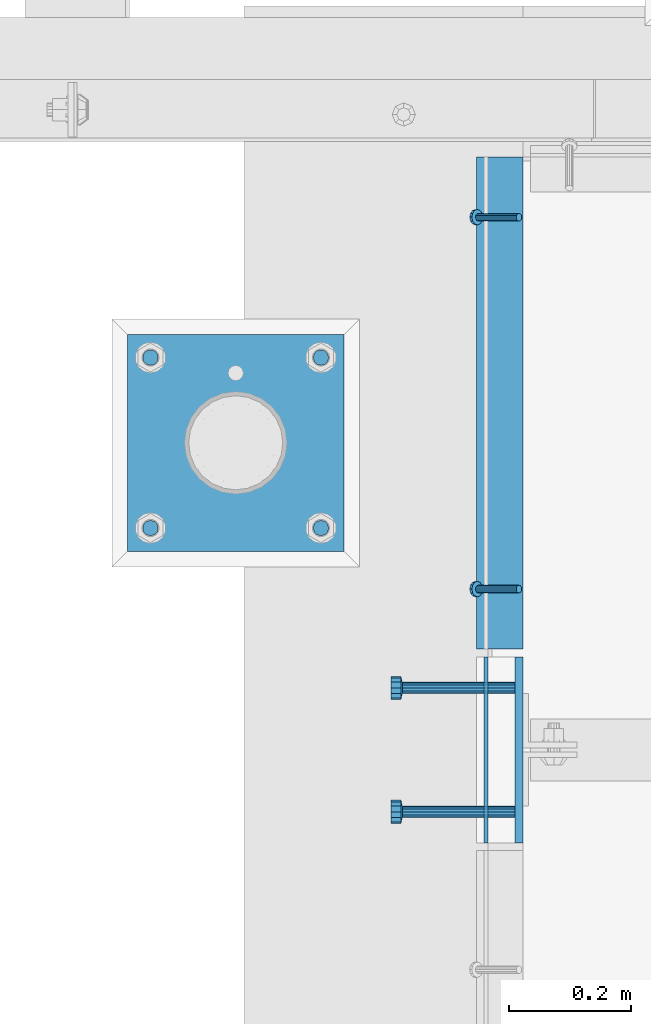
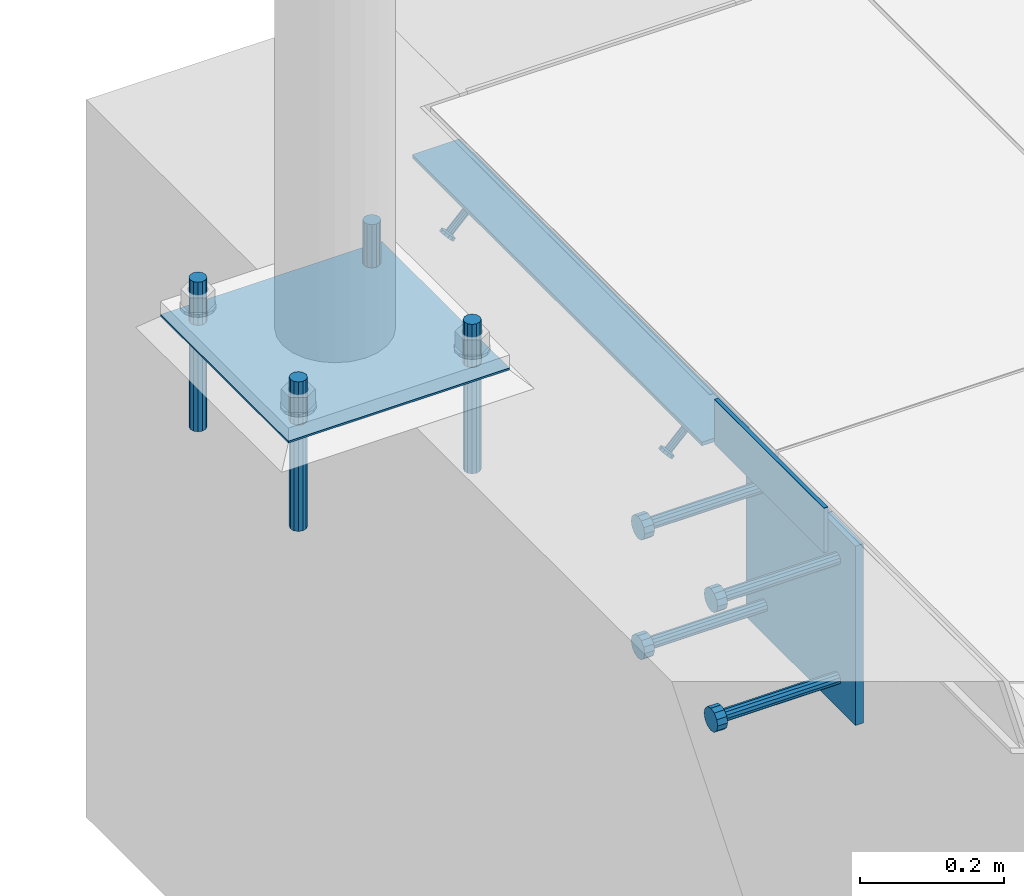
# One storey, part 2018 of 3843: 12 beams, 2 members, 3 elements without a shape of their own.
"""IFC2X3 building model written with IfcOpenShell, lengths in millimetres."""

from ifc_helpers import new_model, si_unit, frame, origin_with_axes, place, context, subcontext, project, spatial, faceted_brep, material, type_object, element, aggregate, save


model = new_model("IFC2X3")

# Units and contexts
model_context = context("Model", 3, precision=1e-05, world=origin_with_axes())
body_context = subcontext(model_context, "Body", "Model", "MODEL_VIEW")
ifc_project = project(units=[si_unit("LENGTHUNIT", "METRE", prefix="MILLI"), si_unit("AREAUNIT", "SQUARE_METRE"), si_unit("VOLUMEUNIT", "CUBIC_METRE"), si_unit("MASSUNIT", "GRAM", prefix="KILO"), si_unit("TIMEUNIT", "SECOND"), si_unit("PLANEANGLEUNIT", "RADIAN"), si_unit("SOLIDANGLEUNIT", "STERADIAN"), si_unit("THERMODYNAMICTEMPERATUREUNIT", "DEGREE_CELSIUS"), si_unit("LUMINOUSINTENSITYUNIT", "LUMEN")], contexts=[model_context])

# Site, building, storey
site_placement = place(None, origin_with_axes())
site = spatial("IfcSite", under=ifc_project, at=site_placement, CompositionType="ELEMENT")
building_placement = place(site_placement, origin_with_axes())
building = spatial("IfcBuilding", under=site, at=building_placement, Name="Undefined", CompositionType="ELEMENT")
storey_placement = place(building_placement, origin_with_axes())
storey = spatial("IfcBuildingStorey", under=building, at=storey_placement, Name="Undefined", CompositionType="ELEMENT", Elevation=0.0)

# Assembly, members
assembly_1_placement = place(storey_placement, origin_with_axes())
assembly_1 = element("IfcElementAssembly", 1, at=assembly_1_placement, inside=storey, Name="ANGLE", AssemblyPlace="NOTDEFINED", PredefinedType="RIGID_FRAME")
ifc_material_1 = material(Name="STEEL/A108")
member_type = type_object("IfcMemberType", PredefinedType="NOTDEFINED")
member_1_placement = place(assembly_1_placement, frame((41411.5249999999, 24272.8750946045, 30397.4500030518), z_axis=(0.0, -1.0, 0.0), x_axis=(-0.707106781186548, 0.0, -0.707106781186548)))
member_1 = element("IfcMember", 2, at=member_1_placement, type_object=member_type, material=ifc_material_1, Name="HEADED STUD ANCHOR", context=body_context, shape_type="Brep", body=[
    faceted_brep([(7.27595761418343e-12, -3.18000006675175, 5.5), (0.0, -5.49999999998363, 3.1800000667572), (94.4879985803855, -5.50000000011278, 3.1800000667572), (94.4879985803782, -3.18000006687362, 5.5), (0.0, -6.3499999046162, 0.0), (94.4879985803855, -6.34999990474535, 0.0), (0.0, -5.49999999998363, -3.1800000667572), (94.4879985803855, -5.50000000011278, -3.1800000667572), (7.27595761418343e-12, -3.18000006675175, -5.5), (94.4879985803782, -3.18000006687362, -5.5), (7.27595761418343e-12, -1.81898940354586e-12, -6.34999990463257), (94.4879985803782, -1.20053300634027e-10, -6.34999990463257), (0.0, 3.18000006675175, -5.5), (94.4879985803709, 3.18000006663351, -5.5), (7.27595761418343e-12, 5.49999999998363, -3.1800000667572), (94.4879985803709, 5.49999999987267, -3.1800000667572), (7.27595761418343e-12, 6.3499999046162, 0.0), (94.4879985803673, 6.34999990450706, 0.0), (7.27595761418343e-12, 5.49999999998363, 3.1800000667572), (94.4879985803709, 5.49999999987267, 3.1800000667572), (0.0, 3.18000006675175, 5.5), (94.4879985803709, 3.18000006663351, 5.5), (7.27595761418343e-12, -1.81898940354586e-12, 6.34999990463257), (94.4879985803782, -1.20053300634027e-10, 6.34999990463257), (96.5199985498621, -10.9899997712273, 6.34999990463257), (96.5199985498548, -6.34000015270249, 10.9899997711182), (96.5199985498621, -12.6999998093743, 0.0), (96.5199985498621, -10.9899997712273, -6.34999990463257), (96.5199985498548, -6.34000015270249, -10.9899997711182), (96.5199985498475, -1.21872290037572e-10, -12.6899995803833), (96.5199985498402, 6.34000015245874, -10.9899997711182), (96.519998549833, 10.9899997709817, -6.34999990463257), (96.519998549833, 12.6999998091305, 0.0), (96.519998549833, 10.9899997709817, 6.34999990463257), (96.5199985498402, 6.34000015245874, 10.9899997711182), (96.5199985498475, -1.21872290037572e-10, 12.6899995803833), (101.599998473539, -10.9899997712328, 6.34999990463257), (101.599998473532, -6.34000015270976, 10.9899997711182), (101.599998473539, -12.6999998093797, 0.0), (101.599998473539, -10.9899997712328, -6.34999990463257), (101.599998473532, -6.34000015270976, -10.9899997711182), (101.599998473524, -1.29148247651756e-10, -12.6899995803833), (101.599998473517, 6.34000015245329, -10.9899997711182), (101.59999847351, 10.9899997709763, -6.34999990463257), (101.599998473503, 12.6999998091196, 0.0), (101.59999847351, 10.9899997709763, 6.34999990463257), (101.599998473517, 6.34000015245329, 10.9899997711182), (101.599998473524, -1.29148247651756e-10, 12.6899995803833)], [[[0, 1, 2, 3]], [[1, 4, 5, 2]], [[4, 6, 7, 5]], [[6, 8, 9, 7]], [[8, 10, 11, 9]], [[10, 12, 13, 11]], [[12, 14, 15, 13]], [[14, 16, 17, 15]], [[16, 18, 19, 17]], [[18, 20, 21, 19]], [[20, 22, 23, 21]], [[22, 0, 3, 23]], [[22, 20, 18, 16, 14, 12, 10, 8, 6, 4, 1, 0]], [[3, 2, 24, 25]], [[2, 5, 26, 24]], [[5, 7, 27, 26]], [[7, 9, 28, 27]], [[9, 11, 29, 28]], [[11, 13, 30, 29]], [[13, 15, 31, 30]], [[15, 17, 32, 31]], [[17, 19, 33, 32]], [[19, 21, 34, 33]], [[21, 23, 35, 34]], [[23, 3, 25, 35]], [[25, 24, 36, 37]], [[24, 26, 38, 36]], [[26, 27, 39, 38]], [[27, 28, 40, 39]], [[28, 29, 41, 40]], [[29, 30, 42, 41]], [[30, 31, 43, 42]], [[31, 32, 44, 43]], [[32, 33, 45, 44]], [[33, 34, 46, 45]], [[34, 35, 47, 46]], [[35, 25, 37, 47]], [[38, 39, 40, 41, 42, 43, 44, 45, 46, 47, 37, 36]]]),
])
member_2_placement = place(assembly_1_placement, frame((41411.5249999999, 24882.4750946045, 30397.4500030518), z_axis=(0.0, -1.0, 0.0), x_axis=(-0.707106781186548, 0.0, -0.707106781186548)))
member_2 = element("IfcMember", 3, at=member_2_placement, type_object=member_type, material=ifc_material_1, Name="HEADED STUD ANCHOR", context=body_context, shape_type="Brep", body=[
    faceted_brep([(7.27595761418343e-12, -3.18000006675175, 5.5), (0.0, -5.49999999998363, 3.1800000667572), (94.4879985803855, -5.50000000011278, 3.1800000667572), (94.4879985803782, -3.18000006687362, 5.5), (0.0, -6.3499999046162, 0.0), (94.4879985803855, -6.34999990474535, 0.0), (0.0, -5.49999999998363, -3.1800000667572), (94.4879985803855, -5.50000000011278, -3.1800000667572), (7.27595761418343e-12, -3.18000006675175, -5.5), (94.4879985803782, -3.18000006687362, -5.5), (7.27595761418343e-12, -1.81898940354586e-12, -6.34999990463257), (94.4879985803782, -1.20053300634027e-10, -6.34999990463257), (0.0, 3.18000006675175, -5.5), (94.4879985803709, 3.18000006663351, -5.5), (7.27595761418343e-12, 5.49999999998363, -3.1800000667572), (94.4879985803709, 5.49999999987267, -3.1800000667572), (7.27595761418343e-12, 6.3499999046162, 0.0), (94.4879985803673, 6.34999990450706, 0.0), (7.27595761418343e-12, 5.49999999998363, 3.1800000667572), (94.4879985803709, 5.49999999987267, 3.1800000667572), (0.0, 3.18000006675175, 5.5), (94.4879985803709, 3.18000006663351, 5.5), (7.27595761418343e-12, -1.81898940354586e-12, 6.34999990463257), (94.4879985803782, -1.20053300634027e-10, 6.34999990463257), (96.5199985498621, -10.9899997712273, 6.34999990463257), (96.5199985498548, -6.34000015270249, 10.9899997711182), (96.5199985498621, -12.6999998093743, 0.0), (96.5199985498621, -10.9899997712273, -6.34999990463257), (96.5199985498548, -6.34000015270249, -10.9899997711182), (96.5199985498475, -1.21872290037572e-10, -12.6899995803833), (96.5199985498402, 6.34000015245874, -10.9899997711182), (96.519998549833, 10.9899997709817, -6.34999990463257), (96.519998549833, 12.6999998091305, 0.0), (96.519998549833, 10.9899997709817, 6.34999990463257), (96.5199985498402, 6.34000015245874, 10.9899997711182), (96.5199985498475, -1.21872290037572e-10, 12.6899995803833), (101.599998473539, -10.9899997712328, 6.34999990463257), (101.599998473532, -6.34000015270976, 10.9899997711182), (101.599998473539, -12.6999998093797, 0.0), (101.599998473539, -10.9899997712328, -6.34999990463257), (101.599998473532, -6.34000015270976, -10.9899997711182), (101.599998473524, -1.29148247651756e-10, -12.6899995803833), (101.599998473517, 6.34000015245329, -10.9899997711182), (101.59999847351, 10.9899997709763, -6.34999990463257), (101.599998473503, 12.6999998091196, 0.0), (101.59999847351, 10.9899997709763, 6.34999990463257), (101.599998473517, 6.34000015245329, 10.9899997711182), (101.599998473524, -1.29148247651756e-10, 12.6899995803833)], [[[0, 1, 2, 3]], [[1, 4, 5, 2]], [[4, 6, 7, 5]], [[6, 8, 9, 7]], [[8, 10, 11, 9]], [[10, 12, 13, 11]], [[12, 14, 15, 13]], [[14, 16, 17, 15]], [[16, 18, 19, 17]], [[18, 20, 21, 19]], [[20, 22, 23, 21]], [[22, 0, 3, 23]], [[22, 20, 18, 16, 14, 12, 10, 8, 6, 4, 1, 0]], [[3, 2, 24, 25]], [[2, 5, 26, 24]], [[5, 7, 27, 26]], [[7, 9, 28, 27]], [[9, 11, 29, 28]], [[11, 13, 30, 29]], [[13, 15, 31, 30]], [[15, 17, 32, 31]], [[17, 19, 33, 32]], [[19, 21, 34, 33]], [[21, 23, 35, 34]], [[23, 3, 25, 35]], [[25, 24, 36, 37]], [[24, 26, 38, 36]], [[26, 27, 39, 38]], [[27, 28, 40, 39]], [[28, 29, 41, 40]], [[29, 30, 42, 41]], [[30, 31, 43, 42]], [[31, 32, 44, 43]], [[32, 33, 45, 44]], [[33, 34, 46, 45]], [[34, 35, 47, 46]], [[35, 25, 37, 47]], [[38, 39, 40, 41, 42, 43, 44, 45, 46, 47, 37, 36]]]),
])

# Assembly, beams
assembly_2_placement = place(storey_placement, origin_with_axes())
assembly_2 = element("IfcElementAssembly", 4, at=assembly_2_placement, inside=storey, Name="TEMPLATE", AssemblyPlace="NOTDEFINED", PredefinedType="RIGID_FRAME")
ifc_material_2 = material(Name="STEEL/316 SS")
beam_type_1 = type_object("IfcBeamType", PredefinedType="NOTDEFINED")
beam_1_placement = place(assembly_2_placement, frame((41086.9793884277, 24372.9638262535, 30581.6), z_axis=(1.0, 0.0, 0.0), x_axis=(0.0, 0.0, -1.0)))
beam_1 = element("IfcBeam", 5, at=beam_1_placement, type_object=beam_type_1, material=ifc_material_2, Name="ANCHOR_ROD", context=body_context, shape_type="Brep", body=[
    faceted_brep([(0.0, -12.6999999999971, 0.0), (0.0, -10.9985226280696, -6.34999999999854), (253.999, -10.9985226280696, -6.34999999999854), (253.999, -12.6999999999971, 0.0), (0.0, -6.35000000000582, -10.9985226280623), (253.999, -6.35000000000582, -10.9985226280623), (0.0, 0.0, -12.6999999999971), (253.999, 0.0, -12.6999999999971), (0.0, 6.35000000000582, -10.9985226280623), (253.999, 6.35000000000582, -10.9985226280623), (0.0, 10.9985226280696, -6.34999999999854), (253.999, 10.9985226280696, -6.34999999999854), (0.0, 12.6999999999971, 0.0), (253.999, 12.6999999999971, 0.0), (0.0, 10.9985226280696, 6.34999999999854), (253.999, 10.9985226280696, 6.34999999999854), (0.0, 6.35000000000582, 10.9985226280623), (253.999, 6.35000000000582, 10.9985226280623), (0.0, 0.0, 12.6999999999971), (253.999, 0.0, 12.6999999999971), (0.0, -6.35000000000582, 10.9985226280623), (253.999, -6.35000000000582, 10.9985226280623), (0.0, -10.9985226280696, 6.34999999999854), (253.999, -10.9985226280696, 6.34999999999854)], [[[0, 1, 2, 3]], [[1, 4, 5, 2]], [[4, 6, 7, 5]], [[6, 8, 9, 7]], [[8, 10, 11, 9]], [[10, 12, 13, 11]], [[12, 14, 15, 13]], [[14, 16, 17, 15]], [[16, 18, 19, 17]], [[18, 20, 21, 19]], [[20, 22, 23, 21]], [[22, 0, 3, 23]], [[5, 7, 9, 11, 13, 15, 17, 19, 21, 23, 3, 2]], [[22, 20, 18, 16, 14, 12, 10, 8, 6, 4, 1, 0]]]),
])
beam_2_placement = place(assembly_2_placement, frame((41086.9793884277, 24652.3638262535, 30581.6), z_axis=(-1.0, 0.0, 0.0), x_axis=(0.0, 0.0, -1.0)))
beam_2 = element("IfcBeam", 6, at=beam_2_placement, type_object=beam_type_1, material=ifc_material_2, Name="ANCHOR_ROD", context=body_context, shape_type="Brep", body=[
    faceted_brep([(0.0, -12.6999999999971, 0.0), (0.0, -10.9985226280696, -6.34999999999854), (253.999, -10.9985226280696, -6.34999999999854), (253.999, -12.6999999999971, 0.0), (0.0, -6.35000000000582, -10.9985226280623), (253.999, -6.35000000000582, -10.9985226280623), (0.0, 0.0, -12.6999999999971), (253.999, 0.0, -12.6999999999971), (0.0, 6.35000000000582, -10.9985226280623), (253.999, 6.35000000000582, -10.9985226280623), (0.0, 10.9985226280696, -6.34999999999854), (253.999, 10.9985226280696, -6.34999999999854), (0.0, 12.6999999999971, 0.0), (253.999, 12.6999999999971, 0.0), (0.0, 10.9985226280696, 6.34999999999854), (253.999, 10.9985226280696, 6.34999999999854), (0.0, 6.35000000000582, 10.9985226280623), (253.999, 6.35000000000582, 10.9985226280623), (0.0, 0.0, 12.6999999999971), (253.999, 0.0, 12.6999999999971), (0.0, -6.35000000000582, 10.9985226280623), (253.999, -6.35000000000582, 10.9985226280623), (0.0, -10.9985226280696, 6.34999999999854), (253.999, -10.9985226280696, 6.34999999999854)], [[[0, 1, 2, 3]], [[1, 4, 5, 2]], [[4, 6, 7, 5]], [[6, 8, 9, 7]], [[8, 10, 11, 9]], [[10, 12, 13, 11]], [[12, 14, 15, 13]], [[14, 16, 17, 15]], [[16, 18, 19, 17]], [[18, 20, 21, 19]], [[20, 22, 23, 21]], [[22, 0, 3, 23]], [[5, 7, 9, 11, 13, 15, 17, 19, 21, 23, 3, 2]], [[22, 20, 18, 16, 14, 12, 10, 8, 6, 4, 1, 0]]]),
])
beam_3_placement = place(assembly_2_placement, frame((40807.5793884277, 24372.9638262535, 30581.6), z_axis=(1.0, 0.0, 0.0), x_axis=(0.0, 0.0, -1.0)))
beam_3 = element("IfcBeam", 7, at=beam_3_placement, type_object=beam_type_1, material=ifc_material_2, Name="ANCHOR_ROD", context=body_context, shape_type="Brep", body=[
    faceted_brep([(0.0, -12.6999999999971, 0.0), (0.0, -10.9985226280696, -6.34999999999854), (253.999, -10.9985226280696, -6.34999999999854), (253.999, -12.6999999999971, 0.0), (0.0, -6.35000000000582, -10.9985226280623), (253.999, -6.35000000000582, -10.9985226280623), (0.0, 0.0, -12.6999999999971), (253.999, 0.0, -12.6999999999971), (0.0, 6.35000000000582, -10.9985226280623), (253.999, 6.35000000000582, -10.9985226280623), (0.0, 10.9985226280696, -6.34999999999854), (253.999, 10.9985226280696, -6.34999999999854), (0.0, 12.6999999999971, 0.0), (253.999, 12.6999999999971, 0.0), (0.0, 10.9985226280696, 6.34999999999854), (253.999, 10.9985226280696, 6.34999999999854), (0.0, 6.35000000000582, 10.9985226280623), (253.999, 6.35000000000582, 10.9985226280623), (0.0, 0.0, 12.6999999999971), (253.999, 0.0, 12.6999999999971), (0.0, -6.35000000000582, 10.9985226280623), (253.999, -6.35000000000582, 10.9985226280623), (0.0, -10.9985226280696, 6.34999999999854), (253.999, -10.9985226280696, 6.34999999999854)], [[[0, 1, 2, 3]], [[1, 4, 5, 2]], [[4, 6, 7, 5]], [[6, 8, 9, 7]], [[8, 10, 11, 9]], [[10, 12, 13, 11]], [[12, 14, 15, 13]], [[14, 16, 17, 15]], [[16, 18, 19, 17]], [[18, 20, 21, 19]], [[20, 22, 23, 21]], [[22, 0, 3, 23]], [[5, 7, 9, 11, 13, 15, 17, 19, 21, 23, 3, 2]], [[22, 20, 18, 16, 14, 12, 10, 8, 6, 4, 1, 0]]]),
])
beam_4_placement = place(assembly_2_placement, frame((40807.5793884277, 24652.3638262535, 30581.6), z_axis=(-1.0, 0.0, 0.0), x_axis=(0.0, 0.0, -1.0)))
beam_4 = element("IfcBeam", 8, at=beam_4_placement, type_object=beam_type_1, material=ifc_material_2, Name="ANCHOR_ROD", context=body_context, shape_type="Brep", body=[
    faceted_brep([(0.0, -12.6999999999971, 0.0), (0.0, -10.9985226280696, -6.34999999999854), (253.999, -10.9985226280696, -6.34999999999854), (253.999, -12.6999999999971, 0.0), (0.0, -6.35000000000582, -10.9985226280623), (253.999, -6.35000000000582, -10.9985226280623), (0.0, 0.0, -12.6999999999971), (253.999, 0.0, -12.6999999999971), (0.0, 6.35000000000582, -10.9985226280623), (253.999, 6.35000000000582, -10.9985226280623), (0.0, 10.9985226280696, -6.34999999999854), (253.999, 10.9985226280696, -6.34999999999854), (0.0, 12.6999999999971, 0.0), (253.999, 12.6999999999971, 0.0), (0.0, 10.9985226280696, 6.34999999999854), (253.999, 10.9985226280696, 6.34999999999854), (0.0, 6.35000000000582, 10.9985226280623), (253.999, 6.35000000000582, 10.9985226280623), (0.0, 0.0, 12.6999999999971), (253.999, 0.0, 12.6999999999971), (0.0, -6.35000000000582, 10.9985226280623), (253.999, -6.35000000000582, 10.9985226280623), (0.0, -10.9985226280696, 6.34999999999854), (253.999, -10.9985226280696, 6.34999999999854)], [[[0, 1, 2, 3]], [[1, 4, 5, 2]], [[4, 6, 7, 5]], [[6, 8, 9, 7]], [[8, 10, 11, 9]], [[10, 12, 13, 11]], [[12, 14, 15, 13]], [[14, 16, 17, 15]], [[16, 18, 19, 17]], [[18, 20, 21, 19]], [[20, 22, 23, 21]], [[22, 0, 3, 23]], [[5, 7, 9, 11, 13, 15, 17, 19, 21, 23, 3, 2]], [[22, 20, 18, 16, 14, 12, 10, 8, 6, 4, 1, 0]]]),
])
ifc_material_3 = material(Name="STEEL/A36")
beam_type_2 = type_object("IfcBeamType", PredefinedType="NOTDEFINED")
beam_5_placement = place(assembly_2_placement, frame((41125.0793884277, 24512.6638262535, 30506.9875), z_axis=(0.0, -1.0, 0.0), x_axis=(-1.0, 0.0, 0.0)))
beam_5 = element("IfcBeam", 9, at=beam_5_placement, type_object=beam_type_2, material=ifc_material_3, Name="TEMPLATE", context=body_context, shape_type="Brep", body=[
    faceted_brep([(0.0, 1.58750000000146, -177.800000000003), (0.0, 1.58750000000146, 177.800000000003), (355.600000000006, 1.58750000000146, 177.800000000003), (355.600000000006, 1.58750000000146, -177.800000000003), (0.0, -1.58750000000146, 177.800000000003), (355.600000000006, -1.58750000000146, 177.800000000003), (0.0, -1.58750000000146, -177.800000000003), (355.600000000006, -1.58750000000146, -177.800000000003)], [[[0, 1, 2, 3]], [[1, 4, 5, 2]], [[4, 6, 7, 5]], [[6, 0, 3, 7]], [[5, 7, 3, 2]], [[6, 4, 1, 0]]]),
])
aggregate(assembly_2, [beam_1, beam_2, beam_3, beam_4, beam_5])

assembly_3_placement = place(storey_placement, origin_with_axes())
assembly_3 = element("IfcElementAssembly", 10, at=assembly_3_placement, inside=storey, Name="EMBED PLATE", AssemblyPlace="NOTDEFINED", PredefinedType="RIGID_FRAME")
beam_type_3 = type_object("IfcBeamType", PredefinedType="NOTDEFINED")
beam_6_placement = place(assembly_3_placement, frame((41357.55, 23856.95, 30441.9), z_axis=(0.0, 0.0, 1.0), x_axis=(0.0, 1.0, 0.0)))
beam_6 = element("IfcBeam", 11, at=beam_6_placement, type_object=beam_type_3, material=ifc_material_3, Name="PLATE", context=body_context, shape_type="Brep", body=[
    faceted_brep([(0.0, 3.17500000000291, -38.0999999999985), (0.0, 3.17500000000291, 38.0999999999985), (304.800000000003, 3.17499999999927, 38.0999999999985), (304.800000000003, 3.17499999999927, -38.0999999999985), (0.0, -3.17500000000291, 38.0999999999985), (304.800000000003, -3.17499999999927, 38.0999999999985), (0.0, -3.17500000000291, -38.0999999999985), (304.800000000003, -3.17499999999927, -38.0999999999985)], [[[0, 1, 2, 3]], [[1, 4, 5, 2]], [[4, 6, 7, 5]], [[6, 0, 3, 7]], [[5, 7, 3, 2]], [[6, 4, 1, 0]]]),
])
beam_type_4 = type_object("IfcBeamType", PredefinedType="NOTDEFINED")
beam_7_placement = place(assembly_3_placement, frame((41411.525, 24009.35, 30397.45), z_axis=(0.0, 1.0, 0.0), x_axis=(0.0, 0.0, -1.0)))
beam_7 = element("IfcBeam", 12, at=beam_7_placement, type_object=beam_type_4, material=ifc_material_3, Name="EMBED PLATE", context=body_context, shape_type="Brep", body=[
    faceted_brep([(-1.0550138540566e-10, 6.34999999999854, -152.400000000664), (1.0550138540566e-10, 6.34999999999854, 152.400000000656), (304.799999999999, 6.34999999999854, 152.400000000001), (304.799999999999, 6.34999999999854, -152.400000000001), (1.0550138540566e-10, -6.34999999999854, 152.400000000656), (304.799999999999, -6.34999999999854, 152.400000000001), (-1.0550138540566e-10, -6.34999999999854, -152.400000000664), (304.799999999999, -6.34999999999854, -152.400000000001)], [[[0, 1, 2, 3]], [[1, 4, 5, 2]], [[4, 6, 7, 5]], [[6, 0, 3, 7]], [[5, 7, 3, 2]], [[6, 4, 1, 0]]]),
])

# Beam
beam_type_5 = type_object("IfcBeamType", Name="L3X3X1/4", PredefinedType="NOTDEFINED")
beam_8_placement = place(assembly_1_placement, frame((41379.775, 24174.4500946045, 30365.7000030518), z_axis=(0.0, 0.0, -1.0), x_axis=(0.0, 1.0, 0.0)))
beam_8 = element("IfcBeam", 13, at=beam_8_placement, type_object=beam_type_5, material=ifc_material_3, Name="ANGLE", ObjectType="L3X3X1/4", context=body_context, shape_type="Brep", body=[
    faceted_brep([(0.0, 38.0999999999985, -38.0999999999985), (0.0, 38.0999999999985, 38.0999999999985), (806.450021508055, 38.0999999999985, 38.0999999999985), (806.450021508055, 38.0999999999985, -38.0999999999985), (0.0, 31.75, 38.0999999999985), (806.450021508055, 31.75, 38.0999999999985), (0.0, 31.75, -31.75), (806.450021508055, 31.75, -31.75), (0.0, -38.0999999999985, -31.75), (806.450021508055, -38.0999999999985, -31.75), (0.0, -38.0999999999985, -38.0999999999985), (806.450021508055, -38.0999999999985, -38.0999999999985)], [[[0, 1, 2, 3]], [[1, 4, 5, 2]], [[4, 6, 7, 5]], [[6, 8, 9, 7]], [[8, 10, 11, 9]], [[10, 0, 3, 11]], [[5, 7, 9, 11, 3, 2]], [[10, 8, 6, 4, 1, 0]]]),
])

aggregate(assembly_1, [member_1, member_2, beam_8])

beam_type_6 = type_object("IfcBeamType", PredefinedType="NOTDEFINED")
beam_9_placement = place(assembly_3_placement, frame((41405.175, 23907.75, 30346.65), z_axis=(0.0, -1.0, 0.0), x_axis=(-1.0, 0.0, 0.0)))
beam_9 = element("IfcBeam", 14, at=beam_9_placement, type_object=beam_type_6, material=ifc_material_1, Name="HEADED STUD ANCHOR", context=body_context, shape_type="Brep", body=[
    faceted_brep([(0.0, -9.52000045776367, 0.0), (0.0, -8.25, -4.76000022888184), (184.912000000004, -8.25, -4.76000022888184), (184.912000000004, -9.52000045776367, 0.0), (0.0, -4.76000022888184, -8.25), (184.912000000004, -4.76000022888184, -8.25), (0.0, 0.0, -9.52000045776367), (184.912000000004, 0.0, -9.52000045776367), (0.0, 4.76000022888184, -8.25), (184.912000000004, 4.76000022888184, -8.25), (0.0, 8.25, -4.76000022888184), (184.912000000004, 8.25, -4.76000022888184), (0.0, 9.52000045776367, 0.0), (184.912000000004, 9.52000045776367, 0.0), (0.0, 8.25, 4.76000022888184), (184.912000000004, 8.25, 4.76000022888184), (0.0, 4.76000022888184, 8.25), (184.912000000004, 4.76000022888184, 8.25), (0.0, 0.0, 9.52000045776367), (184.912000000004, 0.0, 9.52000045776367), (0.0, -4.76000022888184, 8.25), (184.912000000004, -4.76000022888184, 8.25), (0.0, -8.25, 4.76000022888184), (184.912000000004, -8.25, 4.76000022888184), (186.944000000003, -16.5, -9.52000045776367), (186.944000000003, -19.0499992370605, 0.0), (186.944000000003, -9.52000045776367, -16.5), (186.944000000003, 0.0, -19.0499992370605), (186.944000000003, 9.52000045776367, -16.5), (186.944000000003, 16.5, -9.52000045776367), (186.944000000003, 19.0499992370605, 0.0), (186.944000000003, 16.5, 9.52000045776367), (186.944000000003, 9.52000045776367, 16.5), (186.944000000003, 0.0, 19.0499992370605), (186.944000000003, -9.52000045776367, 16.5), (186.944000000003, -16.5, 9.52000045776367), (203.199999999997, -16.5, -9.52000045776367), (203.199999999997, -19.0499992370605, 0.0), (203.199999999997, -9.52000045776367, -16.5), (203.199999999997, 0.0, -19.0499992370605), (203.199999999997, 9.52000045776367, -16.5), (203.199999999997, 16.5, -9.52000045776367), (203.199999999997, 19.0499992370605, 0.0), (203.199999999997, 16.5, 9.52000045776367), (203.199999999997, 9.52000045776367, 16.5), (203.199999999997, 0.0, 19.0499992370605), (203.199999999997, -9.52000045776367, 16.5), (203.199999999997, -16.5, 9.52000045776367)], [[[0, 1, 2, 3]], [[1, 4, 5, 2]], [[4, 6, 7, 5]], [[6, 8, 9, 7]], [[8, 10, 11, 9]], [[10, 12, 13, 11]], [[12, 14, 15, 13]], [[14, 16, 17, 15]], [[16, 18, 19, 17]], [[18, 20, 21, 19]], [[20, 22, 23, 21]], [[22, 0, 3, 23]], [[22, 20, 18, 16, 14, 12, 10, 8, 6, 4, 1, 0]], [[3, 2, 24, 25]], [[2, 5, 26, 24]], [[5, 7, 27, 26]], [[7, 9, 28, 27]], [[9, 11, 29, 28]], [[11, 13, 30, 29]], [[13, 15, 31, 30]], [[15, 17, 32, 31]], [[17, 19, 33, 32]], [[19, 21, 34, 33]], [[21, 23, 35, 34]], [[23, 3, 25, 35]], [[25, 24, 36, 37]], [[24, 26, 38, 36]], [[26, 27, 39, 38]], [[27, 28, 40, 39]], [[28, 29, 41, 40]], [[29, 30, 42, 41]], [[30, 31, 43, 42]], [[31, 32, 44, 43]], [[32, 33, 45, 44]], [[33, 34, 46, 45]], [[34, 35, 47, 46]], [[35, 25, 37, 47]], [[38, 39, 40, 41, 42, 43, 44, 45, 46, 47, 37, 36]]]),
])

beam_10_placement = place(assembly_3_placement, frame((41405.175, 23907.75, 30143.45), z_axis=(0.0, -1.0, 0.0), x_axis=(-1.0, 0.0, 0.0)))
beam_10 = element("IfcBeam", 15, at=beam_10_placement, type_object=beam_type_6, material=ifc_material_1, Name="HEADED STUD ANCHOR", context=body_context, shape_type="Brep", body=[
    faceted_brep([(0.0, -9.52000045776367, 0.0), (0.0, -8.25, -4.76000022888184), (184.912000000004, -8.25, -4.76000022888184), (184.912000000004, -9.52000045776367, 0.0), (0.0, -4.76000022888184, -8.25), (184.912000000004, -4.76000022888184, -8.25), (0.0, 0.0, -9.52000045776367), (184.912000000004, 0.0, -9.52000045776367), (0.0, 4.76000022888184, -8.25), (184.912000000004, 4.76000022888184, -8.25), (0.0, 8.25, -4.76000022888184), (184.912000000004, 8.25, -4.76000022888184), (0.0, 9.52000045776367, 0.0), (184.912000000004, 9.52000045776367, 0.0), (0.0, 8.25, 4.76000022888184), (184.912000000004, 8.25, 4.76000022888184), (0.0, 4.76000022888184, 8.25), (184.912000000004, 4.76000022888184, 8.25), (0.0, 0.0, 9.52000045776367), (184.912000000004, 0.0, 9.52000045776367), (0.0, -4.76000022888184, 8.25), (184.912000000004, -4.76000022888184, 8.25), (0.0, -8.25, 4.76000022888184), (184.912000000004, -8.25, 4.76000022888184), (186.944000000003, -16.5, -9.52000045776367), (186.944000000003, -19.0499992370605, 0.0), (186.944000000003, -9.52000045776367, -16.5), (186.944000000003, 0.0, -19.0499992370605), (186.944000000003, 9.52000045776367, -16.5), (186.944000000003, 16.5, -9.52000045776367), (186.944000000003, 19.0499992370605, 0.0), (186.944000000003, 16.5, 9.52000045776367), (186.944000000003, 9.52000045776367, 16.5), (186.944000000003, 0.0, 19.0499992370605), (186.944000000003, -9.52000045776367, 16.5), (186.944000000003, -16.5, 9.52000045776367), (203.199999999997, -16.5, -9.52000045776367), (203.199999999997, -19.0499992370605, 0.0), (203.199999999997, -9.52000045776367, -16.5), (203.199999999997, 0.0, -19.0499992370605), (203.199999999997, 9.52000045776367, -16.5), (203.199999999997, 16.5, -9.52000045776367), (203.199999999997, 19.0499992370605, 0.0), (203.199999999997, 16.5, 9.52000045776367), (203.199999999997, 9.52000045776367, 16.5), (203.199999999997, 0.0, 19.0499992370605), (203.199999999997, -9.52000045776367, 16.5), (203.199999999997, -16.5, 9.52000045776367)], [[[0, 1, 2, 3]], [[1, 4, 5, 2]], [[4, 6, 7, 5]], [[6, 8, 9, 7]], [[8, 10, 11, 9]], [[10, 12, 13, 11]], [[12, 14, 15, 13]], [[14, 16, 17, 15]], [[16, 18, 19, 17]], [[18, 20, 21, 19]], [[20, 22, 23, 21]], [[22, 0, 3, 23]], [[22, 20, 18, 16, 14, 12, 10, 8, 6, 4, 1, 0]], [[3, 2, 24, 25]], [[2, 5, 26, 24]], [[5, 7, 27, 26]], [[7, 9, 28, 27]], [[9, 11, 29, 28]], [[11, 13, 30, 29]], [[13, 15, 31, 30]], [[15, 17, 32, 31]], [[17, 19, 33, 32]], [[19, 21, 34, 33]], [[21, 23, 35, 34]], [[23, 3, 25, 35]], [[25, 24, 36, 37]], [[24, 26, 38, 36]], [[26, 27, 39, 38]], [[27, 28, 40, 39]], [[28, 29, 41, 40]], [[29, 30, 42, 41]], [[30, 31, 43, 42]], [[31, 32, 44, 43]], [[32, 33, 45, 44]], [[33, 34, 46, 45]], [[34, 35, 47, 46]], [[35, 25, 37, 47]], [[38, 39, 40, 41, 42, 43, 44, 45, 46, 47, 37, 36]]]),
])

beam_11_placement = place(assembly_3_placement, frame((41405.175, 24110.95, 30346.65), z_axis=(0.0, -1.0, 0.0), x_axis=(-1.0, 0.0, 0.0)))
beam_11 = element("IfcBeam", 16, at=beam_11_placement, type_object=beam_type_6, material=ifc_material_3, Name="PLATE", context=body_context, shape_type="Brep", body=[
    faceted_brep([(0.0, -9.52000045776367, 0.0), (0.0, -8.25, -4.76000022888184), (184.912000000004, -8.25, -4.76000022888184), (184.912000000004, -9.52000045776367, 0.0), (0.0, -4.76000022888184, -8.25), (184.912000000004, -4.76000022888184, -8.25), (0.0, 0.0, -9.52000045776367), (184.912000000004, 0.0, -9.52000045776367), (0.0, 4.76000022888184, -8.25), (184.912000000004, 4.76000022888184, -8.25), (0.0, 8.25, -4.76000022888184), (184.912000000004, 8.25, -4.76000022888184), (0.0, 9.52000045776367, 0.0), (184.912000000004, 9.52000045776367, 0.0), (0.0, 8.25, 4.76000022888184), (184.912000000004, 8.25, 4.76000022888184), (0.0, 4.76000022888184, 8.25), (184.912000000004, 4.76000022888184, 8.25), (0.0, 0.0, 9.52000045776367), (184.912000000004, 0.0, 9.52000045776367), (0.0, -4.76000022888184, 8.25), (184.912000000004, -4.76000022888184, 8.25), (0.0, -8.25, 4.76000022888184), (184.912000000004, -8.25, 4.76000022888184), (186.944000000003, -16.5, -9.52000045776367), (186.944000000003, -19.0499992370605, 0.0), (186.944000000003, -9.52000045776367, -16.5), (186.944000000003, 0.0, -19.0499992370605), (186.944000000003, 9.52000045776367, -16.5), (186.944000000003, 16.5, -9.52000045776367), (186.944000000003, 19.0499992370605, 0.0), (186.944000000003, 16.5, 9.52000045776367), (186.944000000003, 9.52000045776367, 16.5), (186.944000000003, 0.0, 19.0499992370605), (186.944000000003, -9.52000045776367, 16.5), (186.944000000003, -16.5, 9.52000045776367), (203.199999999997, -16.5, -9.52000045776367), (203.199999999997, -19.0499992370605, 0.0), (203.199999999997, -9.52000045776367, -16.5), (203.199999999997, 0.0, -19.0499992370605), (203.199999999997, 9.52000045776367, -16.5), (203.199999999997, 16.5, -9.52000045776367), (203.199999999997, 19.0499992370605, 0.0), (203.199999999997, 16.5, 9.52000045776367), (203.199999999997, 9.52000045776367, 16.5), (203.199999999997, 0.0, 19.0499992370605), (203.199999999997, -9.52000045776367, 16.5), (203.199999999997, -16.5, 9.52000045776367)], [[[0, 1, 2, 3]], [[1, 4, 5, 2]], [[4, 6, 7, 5]], [[6, 8, 9, 7]], [[8, 10, 11, 9]], [[10, 12, 13, 11]], [[12, 14, 15, 13]], [[14, 16, 17, 15]], [[16, 18, 19, 17]], [[18, 20, 21, 19]], [[20, 22, 23, 21]], [[22, 0, 3, 23]], [[22, 20, 18, 16, 14, 12, 10, 8, 6, 4, 1, 0]], [[3, 2, 24, 25]], [[2, 5, 26, 24]], [[5, 7, 27, 26]], [[7, 9, 28, 27]], [[9, 11, 29, 28]], [[11, 13, 30, 29]], [[13, 15, 31, 30]], [[15, 17, 32, 31]], [[17, 19, 33, 32]], [[19, 21, 34, 33]], [[21, 23, 35, 34]], [[23, 3, 25, 35]], [[25, 24, 36, 37]], [[24, 26, 38, 36]], [[26, 27, 39, 38]], [[27, 28, 40, 39]], [[28, 29, 41, 40]], [[29, 30, 42, 41]], [[30, 31, 43, 42]], [[31, 32, 44, 43]], [[32, 33, 45, 44]], [[33, 34, 46, 45]], [[34, 35, 47, 46]], [[35, 25, 37, 47]], [[38, 39, 40, 41, 42, 43, 44, 45, 46, 47, 37, 36]]]),
])

beam_12_placement = place(assembly_3_placement, frame((41405.175, 24110.95, 30143.45), z_axis=(0.0, -1.0, 0.0), x_axis=(-1.0, 0.0, 0.0)))
beam_12 = element("IfcBeam", 17, at=beam_12_placement, type_object=beam_type_6, material=ifc_material_1, Name="HEADED STUD ANCHOR", context=body_context, shape_type="Brep", body=[
    faceted_brep([(0.0, -9.52000045776367, 0.0), (0.0, -8.25, -4.76000022888184), (184.912000000004, -8.25, -4.76000022888184), (184.912000000004, -9.52000045776367, 0.0), (0.0, -4.76000022888184, -8.25), (184.912000000004, -4.76000022888184, -8.25), (0.0, 0.0, -9.52000045776367), (184.912000000004, 0.0, -9.52000045776367), (0.0, 4.76000022888184, -8.25), (184.912000000004, 4.76000022888184, -8.25), (0.0, 8.25, -4.76000022888184), (184.912000000004, 8.25, -4.76000022888184), (0.0, 9.52000045776367, 0.0), (184.912000000004, 9.52000045776367, 0.0), (0.0, 8.25, 4.76000022888184), (184.912000000004, 8.25, 4.76000022888184), (0.0, 4.76000022888184, 8.25), (184.912000000004, 4.76000022888184, 8.25), (0.0, 0.0, 9.52000045776367), (184.912000000004, 0.0, 9.52000045776367), (0.0, -4.76000022888184, 8.25), (184.912000000004, -4.76000022888184, 8.25), (0.0, -8.25, 4.76000022888184), (184.912000000004, -8.25, 4.76000022888184), (186.944000000003, -16.5, -9.52000045776367), (186.944000000003, -19.0499992370605, 0.0), (186.944000000003, -9.52000045776367, -16.5), (186.944000000003, 0.0, -19.0499992370605), (186.944000000003, 9.52000045776367, -16.5), (186.944000000003, 16.5, -9.52000045776367), (186.944000000003, 19.0499992370605, 0.0), (186.944000000003, 16.5, 9.52000045776367), (186.944000000003, 9.52000045776367, 16.5), (186.944000000003, 0.0, 19.0499992370605), (186.944000000003, -9.52000045776367, 16.5), (186.944000000003, -16.5, 9.52000045776367), (203.199999999997, -16.5, -9.52000045776367), (203.199999999997, -19.0499992370605, 0.0), (203.199999999997, -9.52000045776367, -16.5), (203.199999999997, 0.0, -19.0499992370605), (203.199999999997, 9.52000045776367, -16.5), (203.199999999997, 16.5, -9.52000045776367), (203.199999999997, 19.0499992370605, 0.0), (203.199999999997, 16.5, 9.52000045776367), (203.199999999997, 9.52000045776367, 16.5), (203.199999999997, 0.0, 19.0499992370605), (203.199999999997, -9.52000045776367, 16.5), (203.199999999997, -16.5, 9.52000045776367)], [[[0, 1, 2, 3]], [[1, 4, 5, 2]], [[4, 6, 7, 5]], [[6, 8, 9, 7]], [[8, 10, 11, 9]], [[10, 12, 13, 11]], [[12, 14, 15, 13]], [[14, 16, 17, 15]], [[16, 18, 19, 17]], [[18, 20, 21, 19]], [[20, 22, 23, 21]], [[22, 0, 3, 23]], [[22, 20, 18, 16, 14, 12, 10, 8, 6, 4, 1, 0]], [[3, 2, 24, 25]], [[2, 5, 26, 24]], [[5, 7, 27, 26]], [[7, 9, 28, 27]], [[9, 11, 29, 28]], [[11, 13, 30, 29]], [[13, 15, 31, 30]], [[15, 17, 32, 31]], [[17, 19, 33, 32]], [[19, 21, 34, 33]], [[21, 23, 35, 34]], [[23, 3, 25, 35]], [[25, 24, 36, 37]], [[24, 26, 38, 36]], [[26, 27, 39, 38]], [[27, 28, 40, 39]], [[28, 29, 41, 40]], [[29, 30, 42, 41]], [[30, 31, 43, 42]], [[31, 32, 44, 43]], [[32, 33, 45, 44]], [[33, 34, 46, 45]], [[34, 35, 47, 46]], [[35, 25, 37, 47]], [[38, 39, 40, 41, 42, 43, 44, 45, 46, 47, 37, 36]]]),
])

aggregate(assembly_3, [beam_6, beam_9, beam_10, beam_11, beam_12, beam_7])

save(model, "model.ifc")
